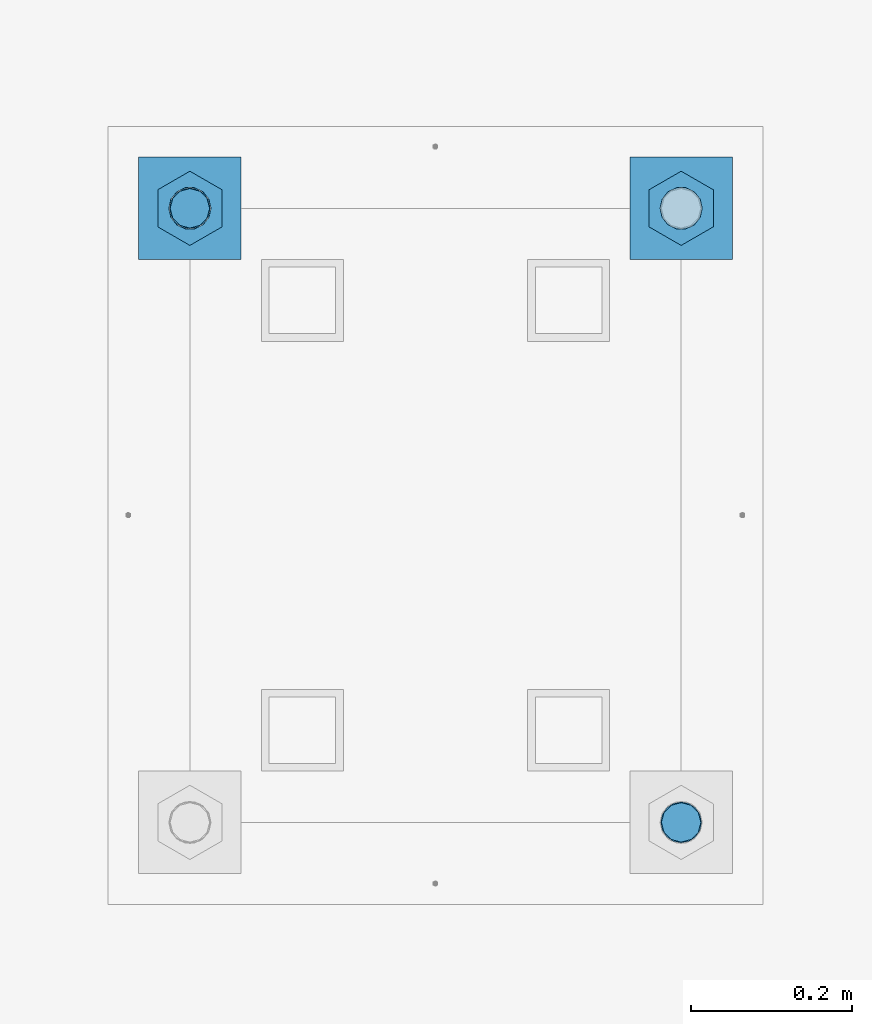
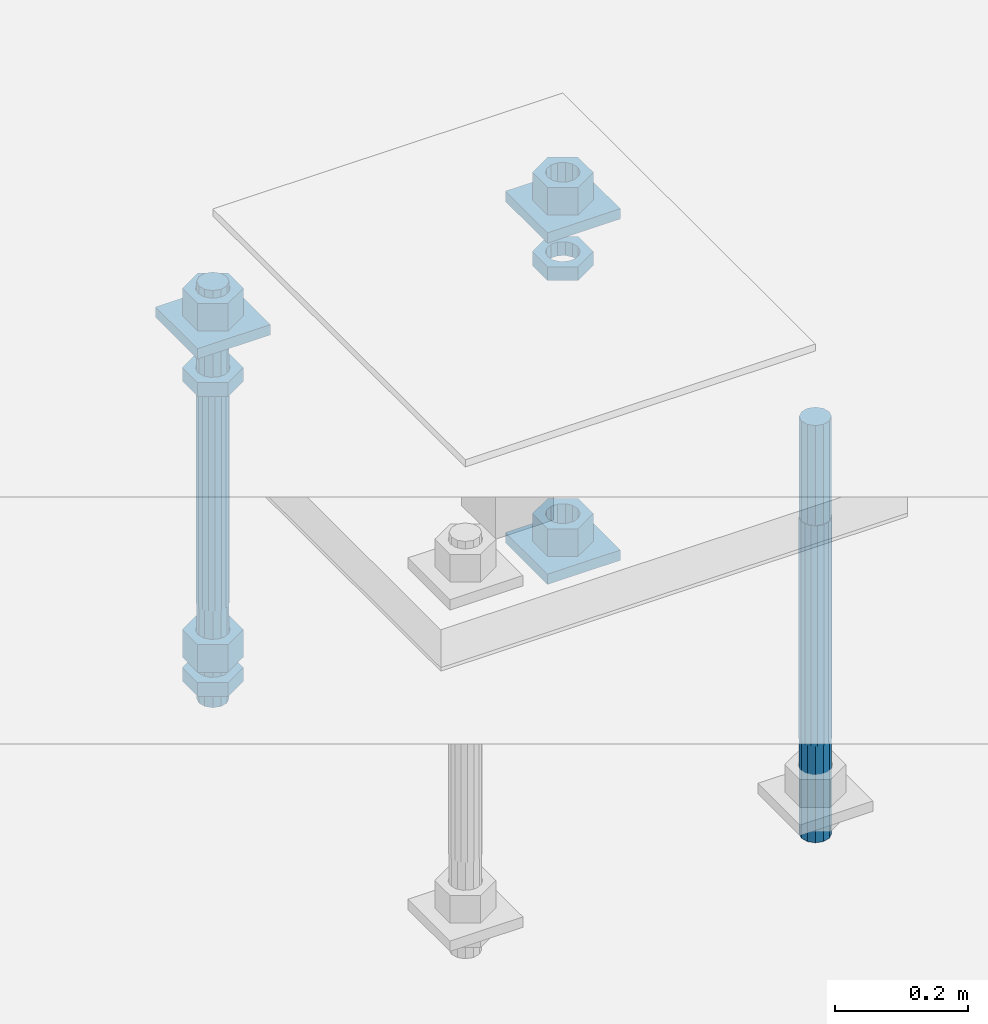
# One storey, part 2643 of 3843: 12 beams, 1 element without a shape of its own.
"""IFC2X3 building model written with IfcOpenShell, lengths in millimetres."""

from ifc_helpers import new_model, si_unit, frame, origin_with_axes, place, context, subcontext, project, spatial, faceted_brep, material, type_object, element, aggregate, save


model = new_model("IFC2X3")

# Units and contexts
model_context = context("Model", 3, precision=1e-05, world=origin_with_axes())
body_context = subcontext(model_context, "Body", "Model", "MODEL_VIEW")
ifc_project = project(units=[si_unit("LENGTHUNIT", "METRE", prefix="MILLI"), si_unit("AREAUNIT", "SQUARE_METRE"), si_unit("VOLUMEUNIT", "CUBIC_METRE"), si_unit("MASSUNIT", "GRAM", prefix="KILO"), si_unit("TIMEUNIT", "SECOND"), si_unit("PLANEANGLEUNIT", "RADIAN"), si_unit("SOLIDANGLEUNIT", "STERADIAN"), si_unit("THERMODYNAMICTEMPERATUREUNIT", "DEGREE_CELSIUS"), si_unit("LUMINOUSINTENSITYUNIT", "LUMEN")], contexts=[model_context])

# Site, building, storey
site_placement = place(None, origin_with_axes())
site = spatial("IfcSite", under=ifc_project, at=site_placement, CompositionType="ELEMENT")
building_placement = place(site_placement, origin_with_axes())
building = spatial("IfcBuilding", under=site, at=building_placement, Name="Undefined", CompositionType="ELEMENT")
storey_placement = place(building_placement, origin_with_axes())
storey = spatial("IfcBuildingStorey", under=building, at=storey_placement, Name="Undefined", CompositionType="ELEMENT", Elevation=0.0)

# Assembly, beams
assembly_placement = place(storey_placement, origin_with_axes())
assembly = element("IfcElementAssembly", 1, at=assembly_placement, inside=storey, Name="TEMPLATE", AssemblyPlace="NOTDEFINED", PredefinedType="RIGID_FRAME")
ifc_material_1 = material(Name="STEEL/A36")
beam_type_1 = type_object("IfcBeamType", PredefinedType="NOTDEFINED")
beam_1_placement = place(assembly_placement, frame((116471.7, 10883.9, 29873.575), z_axis=(0.0, 1.0, 0.0), x_axis=(-1.0, 0.0, 0.0)))
beam_1 = element("IfcBeam", 2, at=beam_1_placement, type_object=beam_type_1, material=ifc_material_1, Name="WASHER_PLATE", context=body_context, shape_type="Brep", body=[
    faceted_brep([(0.0, 9.52500000000146, -63.5), (0.0, 9.52500000000146, 63.5), (127.0, 9.52500000000146, 63.5), (127.0, 9.52500000000146, -63.5), (0.0, -9.52500000000146, 63.5), (127.0, -9.52500000000146, 63.5), (0.0, -9.52500000000146, -63.5), (127.0, -9.52500000000146, -63.5)], [[[0, 1, 2, 3]], [[1, 4, 5, 2]], [[4, 6, 7, 5]], [[6, 0, 3, 7]], [[5, 7, 3, 2]], [[6, 4, 1, 0]]]),
])
beam_2_placement = place(assembly_placement, frame((115862.099998474, 10883.9, 29873.575), z_axis=(0.0, 1.0, 0.0), x_axis=(-1.0, 0.0, 0.0)))
beam_2 = element("IfcBeam", 3, at=beam_2_placement, type_object=beam_type_1, material=ifc_material_1, Name="WASHER_PLATE", context=body_context, shape_type="Brep", body=[
    faceted_brep([(0.0, 9.52500000000146, -63.5), (0.0, 9.52500000000146, 63.5), (127.0, 9.52500000000146, 63.5), (127.0, 9.52500000000146, -63.5), (0.0, -9.52500000000146, 63.5), (127.0, -9.52500000000146, 63.5), (0.0, -9.52500000000146, -63.5), (127.0, -9.52500000000146, -63.5)], [[[0, 1, 2, 3]], [[1, 4, 5, 2]], [[4, 6, 7, 5]], [[6, 0, 3, 7]], [[5, 7, 3, 2]], [[6, 4, 1, 0]]]),
])
beam_3_placement = place(assembly_placement, frame((116471.7, 10883.9, 29244.925), z_axis=(0.0, 1.0, 0.0), x_axis=(-1.0, 0.0, 0.0)))
beam_3 = element("IfcBeam", 4, at=beam_3_placement, type_object=beam_type_1, material=ifc_material_1, Name="WASHER_PLATE", context=body_context, shape_type="Brep", body=[
    faceted_brep([(0.0, 9.52500000000146, -63.5), (0.0, 9.52500000000146, 63.5), (127.0, 9.52500000000146, 63.5), (127.0, 9.52500000000146, -63.5), (0.0, -9.52500000000146, 63.5), (127.0, -9.52500000000146, 63.5), (0.0, -9.52500000000146, -63.5), (127.0, -9.52500000000146, -63.5)], [[[0, 1, 2, 3]], [[1, 4, 5, 2]], [[4, 6, 7, 5]], [[6, 0, 3, 7]], [[5, 7, 3, 2]], [[6, 4, 1, 0]]]),
])
beam_type_2 = type_object("IfcBeamType", Name="2_HALF_NUT", PredefinedType="NOTDEFINED")
beam_4_placement = place(assembly_placement, frame((115798.599998474, 10883.9, 29787.85), z_axis=(-1.0, 0.0, 0.0), x_axis=(0.0, 0.0, -1.0)))
beam_4 = element("IfcBeam", 5, at=beam_4_placement, type_object=beam_type_2, material=ifc_material_1, Name="NUT", ObjectType="2_HALF_NUT", context=body_context, shape_type="Brep", body=[
    faceted_brep([(0.0, -46.0369987487793, 0.0), (0.0, -23.0184993743896, -39.869213104248), (25.4000000000015, -23.0184993743896, -39.869213104248), (25.4000000000015, -46.0369987487793, 0.0), (0.0, 23.0184993743896, -39.869213104248), (25.4000000000015, 23.0184993743896, -39.869213104248), (0.0, 46.0369987487793, 0.0), (25.4000000000015, 46.0369987487793, 0.0), (0.0, 23.0184993743896, 39.869213104248), (25.4000000000015, 23.0184993743896, 39.869213104248), (0.0, -23.0184993743896, 39.869213104248), (25.4000000000015, -23.0184993743896, 39.869213104248), (0.0, 0.0, 26.1940002441406), (0.0, 11.3650617044477, 23.5999013092805), (25.4000000000015, 11.3650617044477, 23.5999013092805), (25.4000000000015, 0.0, 26.1940002441406), (0.0, 20.4791109456419, 16.3316083006721), (25.4000000000015, 20.4791109456419, 16.3316083006721), (0.0, 25.5370200498292, 5.82867859874386), (25.4000000000015, 25.5370200498292, 5.82867859874386), (0.0, 25.5370200498292, -5.82867859874386), (25.4000000000015, 25.5370200498292, -5.82867859874386), (0.0, 20.4791109456419, -16.3316083006721), (25.4000000000015, 20.4791109456419, -16.3316083006721), (0.0, 11.3650617044477, -23.5999013092805), (25.4000000000015, 11.3650617044477, -23.5999013092805), (0.0, 0.0, -26.1940002441406), (25.4000000000015, 0.0, -26.1940002441406), (0.0, -11.3650617044477, -23.5999013092805), (25.4000000000015, -11.3650617044477, -23.5999013092805), (0.0, -20.4791109456419, -16.3316083006721), (25.4000000000015, -20.4791109456419, -16.3316083006721), (0.0, -25.5370200498292, -5.82867859874386), (25.4000000000015, -25.5370200498292, -5.82867859874386), (0.0, -25.5370200498292, 5.82867859874386), (25.4000000000015, -25.5370200498292, 5.82867859874386), (0.0, -20.4791109456419, 16.3316083006721), (25.4000000000015, -20.4791109456419, 16.3316083006721), (0.0, -11.3650617044477, 23.5999013092805), (25.4000000000015, -11.3650617044477, 23.5999013092805)], [[[0, 1, 2, 3]], [[1, 4, 5, 2]], [[4, 6, 7, 5]], [[6, 8, 9, 7]], [[8, 10, 11, 9]], [[10, 0, 3, 11]], [[12, 13, 14, 15]], [[13, 16, 17, 14]], [[16, 18, 19, 17]], [[18, 20, 21, 19]], [[20, 22, 23, 21]], [[22, 24, 25, 23]], [[24, 26, 27, 25]], [[26, 28, 29, 27]], [[28, 30, 31, 29]], [[30, 32, 33, 31]], [[32, 34, 35, 33]], [[34, 36, 37, 35]], [[36, 38, 39, 37]], [[38, 12, 15, 39]], [[5, 7, 9, 11, 3, 2], [17, 19, 21, 23, 25, 27, 29, 31, 33, 35, 37, 39, 15, 14]], [[10, 8, 6, 4, 1, 0], [38, 36, 34, 32, 30, 28, 26, 24, 22, 20, 18, 16, 13, 12]]]),
])
beam_5_placement = place(assembly_placement, frame((115798.599998474, 10883.9, 29235.4), z_axis=(-1.0, 0.0, 0.0), x_axis=(0.0, 0.0, -1.0)))
beam_5 = element("IfcBeam", 6, at=beam_5_placement, type_object=beam_type_2, material=ifc_material_1, Name="NUT", ObjectType="2_HALF_NUT", context=body_context, shape_type="Brep", body=[
    faceted_brep([(0.0, -46.0369987487793, 0.0), (0.0, -23.0184993743896, -39.869213104248), (25.4000000000015, -23.0184993743896, -39.869213104248), (25.4000000000015, -46.0369987487793, 0.0), (0.0, 23.0184993743896, -39.869213104248), (25.4000000000015, 23.0184993743896, -39.869213104248), (0.0, 46.0369987487793, 0.0), (25.4000000000015, 46.0369987487793, 0.0), (0.0, 23.0184993743896, 39.869213104248), (25.4000000000015, 23.0184993743896, 39.869213104248), (0.0, -23.0184993743896, 39.869213104248), (25.4000000000015, -23.0184993743896, 39.869213104248), (0.0, 0.0, 26.1940002441406), (0.0, 11.3650617044477, 23.5999013092805), (25.4000000000015, 11.3650617044477, 23.5999013092805), (25.4000000000015, 0.0, 26.1940002441406), (0.0, 20.4791109456419, 16.3316083006721), (25.4000000000015, 20.4791109456419, 16.3316083006721), (0.0, 25.5370200498292, 5.82867859874386), (25.4000000000015, 25.5370200498292, 5.82867859874386), (0.0, 25.5370200498292, -5.82867859874386), (25.4000000000015, 25.5370200498292, -5.82867859874386), (0.0, 20.4791109456419, -16.3316083006721), (25.4000000000015, 20.4791109456419, -16.3316083006721), (0.0, 11.3650617044477, -23.5999013092805), (25.4000000000015, 11.3650617044477, -23.5999013092805), (0.0, 0.0, -26.1940002441406), (25.4000000000015, 0.0, -26.1940002441406), (0.0, -11.3650617044477, -23.5999013092805), (25.4000000000015, -11.3650617044477, -23.5999013092805), (0.0, -20.4791109456419, -16.3316083006721), (25.4000000000015, -20.4791109456419, -16.3316083006721), (0.0, -25.5370200498292, -5.82867859874386), (25.4000000000015, -25.5370200498292, -5.82867859874386), (0.0, -25.5370200498292, 5.82867859874386), (25.4000000000015, -25.5370200498292, 5.82867859874386), (0.0, -20.4791109456419, 16.3316083006721), (25.4000000000015, -20.4791109456419, 16.3316083006721), (0.0, -11.3650617044477, 23.5999013092805), (25.4000000000015, -11.3650617044477, 23.5999013092805)], [[[0, 1, 2, 3]], [[1, 4, 5, 2]], [[4, 6, 7, 5]], [[6, 8, 9, 7]], [[8, 10, 11, 9]], [[10, 0, 3, 11]], [[12, 13, 14, 15]], [[13, 16, 17, 14]], [[16, 18, 19, 17]], [[18, 20, 21, 19]], [[20, 22, 23, 21]], [[22, 24, 25, 23]], [[24, 26, 27, 25]], [[26, 28, 29, 27]], [[28, 30, 31, 29]], [[30, 32, 33, 31]], [[32, 34, 35, 33]], [[34, 36, 37, 35]], [[36, 38, 39, 37]], [[38, 12, 15, 39]], [[5, 7, 9, 11, 3, 2], [17, 19, 21, 23, 25, 27, 29, 31, 33, 35, 37, 39, 15, 14]], [[10, 8, 6, 4, 1, 0], [38, 36, 34, 32, 30, 28, 26, 24, 22, 20, 18, 16, 13, 12]]]),
])
beam_6_placement = place(assembly_placement, frame((116408.2, 10883.9, 29787.85), z_axis=(-1.0, 0.0, 0.0), x_axis=(0.0, 0.0, -1.0)))
beam_6 = element("IfcBeam", 7, at=beam_6_placement, type_object=beam_type_2, material=ifc_material_1, Name="NUT", ObjectType="2_HALF_NUT", context=body_context, shape_type="Brep", body=[
    faceted_brep([(0.0, -46.0369987487793, 0.0), (0.0, -23.0184993743896, -39.869213104248), (25.4000000000015, -23.0184993743896, -39.869213104248), (25.4000000000015, -46.0369987487793, 0.0), (0.0, 23.0184993743896, -39.869213104248), (25.4000000000015, 23.0184993743896, -39.869213104248), (0.0, 46.0369987487793, 0.0), (25.4000000000015, 46.0369987487793, 0.0), (0.0, 23.0184993743896, 39.869213104248), (25.4000000000015, 23.0184993743896, 39.869213104248), (0.0, -23.0184993743896, 39.869213104248), (25.4000000000015, -23.0184993743896, 39.869213104248), (0.0, 0.0, 26.1940002441406), (0.0, 11.3650617044477, 23.5999013092805), (25.4000000000015, 11.3650617044477, 23.5999013092805), (25.4000000000015, 0.0, 26.1940002441406), (0.0, 20.4791109456419, 16.3316083006721), (25.4000000000015, 20.4791109456419, 16.3316083006721), (0.0, 25.5370200498292, 5.82867859874386), (25.4000000000015, 25.5370200498292, 5.82867859874386), (0.0, 25.5370200498292, -5.82867859874386), (25.4000000000015, 25.5370200498292, -5.82867859874386), (0.0, 20.4791109456419, -16.3316083006721), (25.4000000000015, 20.4791109456419, -16.3316083006721), (0.0, 11.3650617044477, -23.5999013092805), (25.4000000000015, 11.3650617044477, -23.5999013092805), (0.0, 0.0, -26.1940002441406), (25.4000000000015, 0.0, -26.1940002441406), (0.0, -11.3650617044477, -23.5999013092805), (25.4000000000015, -11.3650617044477, -23.5999013092805), (0.0, -20.4791109456419, -16.3316083006721), (25.4000000000015, -20.4791109456419, -16.3316083006721), (0.0, -25.5370200498292, -5.82867859874386), (25.4000000000015, -25.5370200498292, -5.82867859874386), (0.0, -25.5370200498292, 5.82867859874386), (25.4000000000015, -25.5370200498292, 5.82867859874386), (0.0, -20.4791109456419, 16.3316083006721), (25.4000000000015, -20.4791109456419, 16.3316083006721), (0.0, -11.3650617044477, 23.5999013092805), (25.4000000000015, -11.3650617044477, 23.5999013092805)], [[[0, 1, 2, 3]], [[1, 4, 5, 2]], [[4, 6, 7, 5]], [[6, 8, 9, 7]], [[8, 10, 11, 9]], [[10, 0, 3, 11]], [[12, 13, 14, 15]], [[13, 16, 17, 14]], [[16, 18, 19, 17]], [[18, 20, 21, 19]], [[20, 22, 23, 21]], [[22, 24, 25, 23]], [[24, 26, 27, 25]], [[26, 28, 29, 27]], [[28, 30, 31, 29]], [[30, 32, 33, 31]], [[32, 34, 35, 33]], [[34, 36, 37, 35]], [[36, 38, 39, 37]], [[38, 12, 15, 39]], [[5, 7, 9, 11, 3, 2], [17, 19, 21, 23, 25, 27, 29, 31, 33, 35, 37, 39, 15, 14]], [[10, 8, 6, 4, 1, 0], [38, 36, 34, 32, 30, 28, 26, 24, 22, 20, 18, 16, 13, 12]]]),
])
beam_type_3 = type_object("IfcBeamType", Name="2_HEAVY_HEX_NUT", PredefinedType="NOTDEFINED")
beam_7_placement = place(assembly_placement, frame((115798.599998474, 10883.9, 29933.9), z_axis=(-1.0, 0.0, 0.0), x_axis=(0.0, 0.0, -1.0)))
beam_7 = element("IfcBeam", 8, at=beam_7_placement, type_object=beam_type_3, material=ifc_material_1, Name="NUT", ObjectType="2_HEAVY_HEX_NUT", context=body_context, shape_type="Brep", body=[
    faceted_brep([(0.0, -46.0369987487793, 0.0), (0.0, -23.0184993743896, -39.869213104248), (50.7999999999993, -23.0184993743896, -39.869213104248), (50.7999999999993, -46.0369987487793, 0.0), (0.0, 23.0184993743896, -39.869213104248), (50.7999999999993, 23.0184993743896, -39.869213104248), (0.0, 46.0369987487793, 0.0), (50.7999999999993, 46.0369987487793, 0.0), (0.0, 23.0184993743896, 39.869213104248), (50.7999999999993, 23.0184993743896, 39.869213104248), (0.0, -23.0184993743896, 39.869213104248), (50.7999999999993, -23.0184993743896, 39.869213104248), (0.0, 0.0, 26.1940002441406), (0.0, 11.3650617044477, 23.5999013092805), (50.7999999999993, 11.3650617044477, 23.5999013092805), (50.7999999999993, 0.0, 26.1940002441406), (0.0, 20.4791109456419, 16.3316083006721), (50.7999999999993, 20.4791109456419, 16.3316083006721), (0.0, 25.5370200498292, 5.82867859874386), (50.7999999999993, 25.5370200498292, 5.82867859874386), (0.0, 25.5370200498292, -5.82867859874386), (50.7999999999993, 25.5370200498292, -5.82867859874386), (0.0, 20.4791109456419, -16.3316083006721), (50.7999999999993, 20.4791109456419, -16.3316083006721), (0.0, 11.3650617044477, -23.5999013092805), (50.7999999999993, 11.3650617044477, -23.5999013092805), (0.0, 0.0, -26.1940002441406), (50.7999999999993, 0.0, -26.1940002441406), (0.0, -11.3650617044477, -23.5999013092805), (50.7999999999993, -11.3650617044477, -23.5999013092805), (0.0, -20.4791109456419, -16.3316083006721), (50.7999999999993, -20.4791109456419, -16.3316083006721), (0.0, -25.5370200498292, -5.82867859874386), (50.7999999999993, -25.5370200498292, -5.82867859874386), (0.0, -25.5370200498292, 5.82867859874386), (50.7999999999993, -25.5370200498292, 5.82867859874386), (0.0, -20.4791109456419, 16.3316083006721), (50.7999999999993, -20.4791109456419, 16.3316083006721), (0.0, -11.3650617044477, 23.5999013092805), (50.7999999999993, -11.3650617044477, 23.5999013092805)], [[[0, 1, 2, 3]], [[1, 4, 5, 2]], [[4, 6, 7, 5]], [[6, 8, 9, 7]], [[8, 10, 11, 9]], [[10, 0, 3, 11]], [[12, 13, 14, 15]], [[13, 16, 17, 14]], [[16, 18, 19, 17]], [[18, 20, 21, 19]], [[20, 22, 23, 21]], [[22, 24, 25, 23]], [[24, 26, 27, 25]], [[26, 28, 29, 27]], [[28, 30, 31, 29]], [[30, 32, 33, 31]], [[32, 34, 35, 33]], [[34, 36, 37, 35]], [[36, 38, 39, 37]], [[38, 12, 15, 39]], [[5, 7, 9, 11, 3, 2], [17, 19, 21, 23, 25, 27, 29, 31, 33, 35, 37, 39, 15, 14]], [[10, 8, 6, 4, 1, 0], [38, 36, 34, 32, 30, 28, 26, 24, 22, 20, 18, 16, 13, 12]]]),
])
beam_8_placement = place(assembly_placement, frame((115798.599998474, 10883.9, 29305.25), z_axis=(-1.0, 0.0, 0.0), x_axis=(0.0, 0.0, -1.0)))
beam_8 = element("IfcBeam", 9, at=beam_8_placement, type_object=beam_type_3, material=ifc_material_1, Name="NUT", ObjectType="2_HEAVY_HEX_NUT", context=body_context, shape_type="Brep", body=[
    faceted_brep([(0.0, -46.0369987487793, 0.0), (0.0, -23.0184993743896, -39.869213104248), (50.7999999999993, -23.0184993743896, -39.869213104248), (50.7999999999993, -46.0369987487793, 0.0), (0.0, 23.0184993743896, -39.869213104248), (50.7999999999993, 23.0184993743896, -39.869213104248), (0.0, 46.0369987487793, 0.0), (50.7999999999993, 46.0369987487793, 0.0), (0.0, 23.0184993743896, 39.869213104248), (50.7999999999993, 23.0184993743896, 39.869213104248), (0.0, -23.0184993743896, 39.869213104248), (50.7999999999993, -23.0184993743896, 39.869213104248), (0.0, 0.0, 26.1940002441406), (0.0, 11.3650617044477, 23.5999013092805), (50.7999999999993, 11.3650617044477, 23.5999013092805), (50.7999999999993, 0.0, 26.1940002441406), (0.0, 20.4791109456419, 16.3316083006721), (50.7999999999993, 20.4791109456419, 16.3316083006721), (0.0, 25.5370200498292, 5.82867859874386), (50.7999999999993, 25.5370200498292, 5.82867859874386), (0.0, 25.5370200498292, -5.82867859874386), (50.7999999999993, 25.5370200498292, -5.82867859874386), (0.0, 20.4791109456419, -16.3316083006721), (50.7999999999993, 20.4791109456419, -16.3316083006721), (0.0, 11.3650617044477, -23.5999013092805), (50.7999999999993, 11.3650617044477, -23.5999013092805), (0.0, 0.0, -26.1940002441406), (50.7999999999993, 0.0, -26.1940002441406), (0.0, -11.3650617044477, -23.5999013092805), (50.7999999999993, -11.3650617044477, -23.5999013092805), (0.0, -20.4791109456419, -16.3316083006721), (50.7999999999993, -20.4791109456419, -16.3316083006721), (0.0, -25.5370200498292, -5.82867859874386), (50.7999999999993, -25.5370200498292, -5.82867859874386), (0.0, -25.5370200498292, 5.82867859874386), (50.7999999999993, -25.5370200498292, 5.82867859874386), (0.0, -20.4791109456419, 16.3316083006721), (50.7999999999993, -20.4791109456419, 16.3316083006721), (0.0, -11.3650617044477, 23.5999013092805), (50.7999999999993, -11.3650617044477, 23.5999013092805)], [[[0, 1, 2, 3]], [[1, 4, 5, 2]], [[4, 6, 7, 5]], [[6, 8, 9, 7]], [[8, 10, 11, 9]], [[10, 0, 3, 11]], [[12, 13, 14, 15]], [[13, 16, 17, 14]], [[16, 18, 19, 17]], [[18, 20, 21, 19]], [[20, 22, 23, 21]], [[22, 24, 25, 23]], [[24, 26, 27, 25]], [[26, 28, 29, 27]], [[28, 30, 31, 29]], [[30, 32, 33, 31]], [[32, 34, 35, 33]], [[34, 36, 37, 35]], [[36, 38, 39, 37]], [[38, 12, 15, 39]], [[5, 7, 9, 11, 3, 2], [17, 19, 21, 23, 25, 27, 29, 31, 33, 35, 37, 39, 15, 14]], [[10, 8, 6, 4, 1, 0], [38, 36, 34, 32, 30, 28, 26, 24, 22, 20, 18, 16, 13, 12]]]),
])
beam_9_placement = place(assembly_placement, frame((116408.2, 10883.9, 29933.9), z_axis=(-1.0, 0.0, 0.0), x_axis=(0.0, 0.0, -1.0)))
beam_9 = element("IfcBeam", 10, at=beam_9_placement, type_object=beam_type_3, material=ifc_material_1, Name="NUT", ObjectType="2_HEAVY_HEX_NUT", context=body_context, shape_type="Brep", body=[
    faceted_brep([(0.0, -46.0369987487793, 0.0), (0.0, -23.0184993743896, -39.869213104248), (50.7999999999993, -23.0184993743896, -39.869213104248), (50.7999999999993, -46.0369987487793, 0.0), (0.0, 23.0184993743896, -39.869213104248), (50.7999999999993, 23.0184993743896, -39.869213104248), (0.0, 46.0369987487793, 0.0), (50.7999999999993, 46.0369987487793, 0.0), (0.0, 23.0184993743896, 39.869213104248), (50.7999999999993, 23.0184993743896, 39.869213104248), (0.0, -23.0184993743896, 39.869213104248), (50.7999999999993, -23.0184993743896, 39.869213104248), (0.0, 0.0, 26.1940002441406), (0.0, 11.3650617044477, 23.5999013092805), (50.7999999999993, 11.3650617044477, 23.5999013092805), (50.7999999999993, 0.0, 26.1940002441406), (0.0, 20.4791109456419, 16.3316083006721), (50.7999999999993, 20.4791109456419, 16.3316083006721), (0.0, 25.5370200498292, 5.82867859874386), (50.7999999999993, 25.5370200498292, 5.82867859874386), (0.0, 25.5370200498292, -5.82867859874386), (50.7999999999993, 25.5370200498292, -5.82867859874386), (0.0, 20.4791109456419, -16.3316083006721), (50.7999999999993, 20.4791109456419, -16.3316083006721), (0.0, 11.3650617044477, -23.5999013092805), (50.7999999999993, 11.3650617044477, -23.5999013092805), (0.0, 0.0, -26.1940002441406), (50.7999999999993, 0.0, -26.1940002441406), (0.0, -11.3650617044477, -23.5999013092805), (50.7999999999993, -11.3650617044477, -23.5999013092805), (0.0, -20.4791109456419, -16.3316083006721), (50.7999999999993, -20.4791109456419, -16.3316083006721), (0.0, -25.5370200498292, -5.82867859874386), (50.7999999999993, -25.5370200498292, -5.82867859874386), (0.0, -25.5370200498292, 5.82867859874386), (50.7999999999993, -25.5370200498292, 5.82867859874386), (0.0, -20.4791109456419, 16.3316083006721), (50.7999999999993, -20.4791109456419, 16.3316083006721), (0.0, -11.3650617044477, 23.5999013092805), (50.7999999999993, -11.3650617044477, 23.5999013092805)], [[[0, 1, 2, 3]], [[1, 4, 5, 2]], [[4, 6, 7, 5]], [[6, 8, 9, 7]], [[8, 10, 11, 9]], [[10, 0, 3, 11]], [[12, 13, 14, 15]], [[13, 16, 17, 14]], [[16, 18, 19, 17]], [[18, 20, 21, 19]], [[20, 22, 23, 21]], [[22, 24, 25, 23]], [[24, 26, 27, 25]], [[26, 28, 29, 27]], [[28, 30, 31, 29]], [[30, 32, 33, 31]], [[32, 34, 35, 33]], [[34, 36, 37, 35]], [[36, 38, 39, 37]], [[38, 12, 15, 39]], [[5, 7, 9, 11, 3, 2], [17, 19, 21, 23, 25, 27, 29, 31, 33, 35, 37, 39, 15, 14]], [[10, 8, 6, 4, 1, 0], [38, 36, 34, 32, 30, 28, 26, 24, 22, 20, 18, 16, 13, 12]]]),
])
beam_10_placement = place(assembly_placement, frame((116408.2, 10883.9, 29305.25), z_axis=(-1.0, 0.0, 0.0), x_axis=(0.0, 0.0, -1.0)))
beam_10 = element("IfcBeam", 11, at=beam_10_placement, type_object=beam_type_3, material=ifc_material_1, Name="NUT", ObjectType="2_HEAVY_HEX_NUT", context=body_context, shape_type="Brep", body=[
    faceted_brep([(0.0, -46.0369987487793, 0.0), (0.0, -23.0184993743896, -39.869213104248), (50.7999999999993, -23.0184993743896, -39.869213104248), (50.7999999999993, -46.0369987487793, 0.0), (0.0, 23.0184993743896, -39.869213104248), (50.7999999999993, 23.0184993743896, -39.869213104248), (0.0, 46.0369987487793, 0.0), (50.7999999999993, 46.0369987487793, 0.0), (0.0, 23.0184993743896, 39.869213104248), (50.7999999999993, 23.0184993743896, 39.869213104248), (0.0, -23.0184993743896, 39.869213104248), (50.7999999999993, -23.0184993743896, 39.869213104248), (0.0, 0.0, 26.1940002441406), (0.0, 11.3650617044477, 23.5999013092805), (50.7999999999993, 11.3650617044477, 23.5999013092805), (50.7999999999993, 0.0, 26.1940002441406), (0.0, 20.4791109456419, 16.3316083006721), (50.7999999999993, 20.4791109456419, 16.3316083006721), (0.0, 25.5370200498292, 5.82867859874386), (50.7999999999993, 25.5370200498292, 5.82867859874386), (0.0, 25.5370200498292, -5.82867859874386), (50.7999999999993, 25.5370200498292, -5.82867859874386), (0.0, 20.4791109456419, -16.3316083006721), (50.7999999999993, 20.4791109456419, -16.3316083006721), (0.0, 11.3650617044477, -23.5999013092805), (50.7999999999993, 11.3650617044477, -23.5999013092805), (0.0, 0.0, -26.1940002441406), (50.7999999999993, 0.0, -26.1940002441406), (0.0, -11.3650617044477, -23.5999013092805), (50.7999999999993, -11.3650617044477, -23.5999013092805), (0.0, -20.4791109456419, -16.3316083006721), (50.7999999999993, -20.4791109456419, -16.3316083006721), (0.0, -25.5370200498292, -5.82867859874386), (50.7999999999993, -25.5370200498292, -5.82867859874386), (0.0, -25.5370200498292, 5.82867859874386), (50.7999999999993, -25.5370200498292, 5.82867859874386), (0.0, -20.4791109456419, 16.3316083006721), (50.7999999999993, -20.4791109456419, 16.3316083006721), (0.0, -11.3650617044477, 23.5999013092805), (50.7999999999993, -11.3650617044477, 23.5999013092805)], [[[0, 1, 2, 3]], [[1, 4, 5, 2]], [[4, 6, 7, 5]], [[6, 8, 9, 7]], [[8, 10, 11, 9]], [[10, 0, 3, 11]], [[12, 13, 14, 15]], [[13, 16, 17, 14]], [[16, 18, 19, 17]], [[18, 20, 21, 19]], [[20, 22, 23, 21]], [[22, 24, 25, 23]], [[24, 26, 27, 25]], [[26, 28, 29, 27]], [[28, 30, 31, 29]], [[30, 32, 33, 31]], [[32, 34, 35, 33]], [[34, 36, 37, 35]], [[36, 38, 39, 37]], [[38, 12, 15, 39]], [[5, 7, 9, 11, 3, 2], [17, 19, 21, 23, 25, 27, 29, 31, 33, 35, 37, 39, 15, 14]], [[10, 8, 6, 4, 1, 0], [38, 36, 34, 32, 30, 28, 26, 24, 22, 20, 18, 16, 13, 12]]]),
])
ifc_material_2 = material()
beam_type_4 = type_object("IfcBeamType", PredefinedType="NOTDEFINED")
beam_11_placement = place(assembly_placement, frame((115798.599998474, 10883.9, 29762.45), z_axis=(-1.0, 0.0, 0.0), x_axis=(0.0, 0.0, -1.0)))
beam_11 = element("IfcBeam", 12, at=beam_11_placement, type_object=beam_type_4, material=ifc_material_2, Name="ANCHOR_ROD", context=body_context, shape_type="Brep", body=[
    faceted_brep([(-184.150000000001, -21.217622392709, 12.25), (-184.150000000001, -12.2499999999854, 21.2176223927163), (-184.150000000001, 1.45519152283669e-11, 24.5), (-184.150000000001, 12.2500000000146, 21.2176223927163), (-184.150000000001, 21.2176223927381, 12.25), (-184.150000000001, 24.5000000000146, 0.0), (-184.150000000001, 21.2176223927381, -12.25), (-184.150000000001, 12.2500000000146, -21.2176223927163), (-184.150000000001, 1.45519152283669e-11, -24.5), (-184.150000000001, -12.2499999999854, -21.2176223927163), (-184.150000000001, -21.217622392709, -12.25), (-184.150000000001, -24.4999999999854, 0.0), (0.0, 24.5000000000146, 0.0), (0.0, 21.2176223927381, -12.25), (0.0, 12.2500000000146, -21.2176223927163), (0.0, 1.45519152283669e-11, -24.5), (0.0, -12.2499999999854, -21.2176223927163), (0.0, -21.217622392709, -12.25), (0.0, -24.4999999999854, 0.0), (0.0, -21.217622392709, 12.25), (0.0, -12.2499999999854, 21.2176223927163), (0.0, 1.45519152283669e-11, 24.5), (0.0, 12.2500000000146, 21.2176223927163), (0.0, 21.2176223927381, 12.25), (0.0, -23.4665401257807, 9.72015918207035), (0.0, -17.9605122421344, 17.9605122421417), (0.0, -9.72015918207762, 23.466540125788), (0.0, 0.0, 25.4000000000015), (0.0, 9.72015918207762, 23.466540125788), (0.0, 17.9605122421344, 17.9605122421417), (0.0, 23.4665401257807, 9.72015918207035), (0.0, 25.3999996185303, 0.0), (0.0, 23.4665401257807, -9.72015918207035), (0.0, 17.9605122421344, -17.9605122421417), (0.0, 9.72015918207762, -23.466540125788), (0.0, 0.0, -25.4000000000015), (0.0, -9.72015918207762, -23.466540125788), (0.0, -17.9605122421344, -17.9605122421417), (0.0, -23.4665401257807, -9.72015918207035), (0.0, -25.3999996185303, 0.0), (406.399999999998, -25.3999999999942, 0.0), (406.399999999998, -23.4665401257807, 9.72015918207035), (406.399999999998, -17.9605122421344, 17.9605122421417), (406.399999999998, -9.72015918207762, 23.466540125788), (406.399999999998, 0.0, 25.4000000000015), (406.399999999998, 9.72015918207762, 23.466540125788), (406.399999999998, 17.9605122421344, 17.9605122421417), (406.399999999998, 23.4665401257807, 9.72015918207035), (406.399999999998, 25.3999999999942, 0.0), (406.399999999998, 23.4665401257807, -9.72015918207035), (406.399999999998, 17.9605122421344, -17.9605122421417), (406.399999999998, 9.72015918207762, -23.466540125788), (406.399999999998, 0.0, -25.4000000000015), (406.399999999998, -9.72015918207762, -23.466540125788), (406.399999999998, -17.9605122421344, -17.9605122421417), (406.399999999998, -23.4665401257807, -9.72015918207035), (406.399999999998, -12.2499999999854, 21.2176223927163), (406.399999999998, 1.45519152283669e-11, 24.5), (406.399999999998, 12.2500000000146, 21.2176223927163), (406.399999999998, 21.2176223927381, 12.25), (406.399999999998, 24.5000000000146, 0.0), (406.399999999998, 21.2176223927381, -12.25), (406.399999999998, 12.2500000000146, -21.2176223927163), (406.399999999998, 1.45519152283669e-11, -24.5), (406.399999999998, -12.2499999999854, -21.2176223927163), (406.399999999998, -21.217622392709, -12.25), (406.399999999998, -24.4999999999854, 0.0), (406.399999999998, -21.217622392709, 12.25), (584.200000000001, -12.2499999999854, -21.2176223927163), (584.200000000001, 1.45519152283669e-11, -24.5), (584.200000000001, 12.2500000000146, -21.2176223927163), (584.200000000001, 21.2176223927381, -12.25), (584.200000000001, 24.5000000000146, 0.0), (584.200000000001, 21.2176223927381, 12.25), (584.200000000001, 12.2500000000146, 21.2176223927163), (584.200000000001, 1.45519152283669e-11, 24.5), (584.200000000001, -12.2499999999854, 21.2176223927163), (584.200000000001, -21.217622392709, 12.25), (584.200000000001, -24.4999999999854, 0.0), (584.200000000001, -21.217622392709, -12.25)], [[[0, 1, 2, 3, 4, 5, 6, 7, 8, 9, 10, 11]], [[6, 5, 12, 13]], [[7, 6, 13, 14]], [[8, 7, 14, 15]], [[9, 8, 15, 16]], [[10, 9, 16, 17]], [[11, 10, 17, 18]], [[0, 11, 18, 19]], [[1, 0, 19, 20]], [[2, 1, 20, 21]], [[3, 2, 21, 22]], [[4, 3, 22, 23]], [[5, 4, 23, 12]], [[24, 25, 26, 27, 28, 29, 30, 31, 32, 33, 34, 35, 36, 37, 38, 39], [22, 21, 20, 19, 18, 17, 16, 15, 14, 13, 12, 23]], [[24, 39, 40, 41]], [[25, 24, 41, 42]], [[26, 25, 42, 43]], [[27, 26, 43, 44]], [[28, 27, 44, 45]], [[29, 28, 45, 46]], [[30, 29, 46, 47]], [[31, 30, 47, 48]], [[32, 31, 48, 49]], [[33, 32, 49, 50]], [[34, 33, 50, 51]], [[35, 34, 51, 52]], [[36, 35, 52, 53]], [[37, 36, 53, 54]], [[38, 37, 54, 55]], [[39, 38, 55, 40]], [[54, 53, 52, 51, 50, 49, 48, 47, 46, 45, 44, 43, 42, 41, 40, 55], [56, 57, 58, 59, 60, 61, 62, 63, 64, 65, 66, 67]], [[68, 69, 70, 71, 72, 73, 74, 75, 76, 77, 78, 79]], [[76, 75, 57, 56]], [[77, 76, 56, 67]], [[78, 77, 67, 66]], [[79, 78, 66, 65]], [[68, 79, 65, 64]], [[69, 68, 64, 63]], [[70, 69, 63, 62]], [[71, 70, 62, 61]], [[72, 71, 61, 60]], [[73, 72, 60, 59]], [[74, 73, 59, 58]], [[75, 74, 58, 57]]]),
])
beam_12_placement = place(assembly_placement, frame((116408.2, 10121.9, 29762.45), z_axis=(-1.0, 0.0, 0.0), x_axis=(0.0, 0.0, -1.0)))
beam_12 = element("IfcBeam", 13, at=beam_12_placement, type_object=beam_type_4, material=ifc_material_2, Name="ANCHOR_ROD", context=body_context, shape_type="Brep", body=[
    faceted_brep([(-184.150000000001, -21.217622392709, 12.25), (-184.150000000001, -12.2499999999854, 21.2176223927163), (-184.150000000001, 1.45519152283669e-11, 24.5), (-184.150000000001, 12.2500000000146, 21.2176223927163), (-184.150000000001, 21.2176223927381, 12.25), (-184.150000000001, 24.5000000000146, 0.0), (-184.150000000001, 21.2176223927381, -12.25), (-184.150000000001, 12.2500000000146, -21.2176223927163), (-184.150000000001, 1.45519152283669e-11, -24.5), (-184.150000000001, -12.2499999999854, -21.2176223927163), (-184.150000000001, -21.217622392709, -12.25), (-184.150000000001, -24.4999999999854, 0.0), (0.0, 24.5000000000146, 0.0), (0.0, 21.2176223927381, -12.25), (0.0, 12.2500000000146, -21.2176223927163), (0.0, 1.45519152283669e-11, -24.5), (0.0, -12.2499999999854, -21.2176223927163), (0.0, -21.217622392709, -12.25), (0.0, -24.4999999999854, 0.0), (0.0, -21.217622392709, 12.25), (0.0, -12.2499999999854, 21.2176223927163), (0.0, 1.45519152283669e-11, 24.5), (0.0, 12.2500000000146, 21.2176223927163), (0.0, 21.2176223927381, 12.25), (0.0, -23.4665401257807, 9.72015918207035), (0.0, -17.9605122421344, 17.9605122421417), (0.0, -9.72015918207762, 23.466540125788), (0.0, 0.0, 25.4000000000015), (0.0, 9.72015918207762, 23.466540125788), (0.0, 17.9605122421344, 17.9605122421417), (0.0, 23.4665401257807, 9.72015918207035), (0.0, 25.3999996185303, 0.0), (0.0, 23.4665401257807, -9.72015918207035), (0.0, 17.9605122421344, -17.9605122421417), (0.0, 9.72015918207762, -23.466540125788), (0.0, 0.0, -25.4000000000015), (0.0, -9.72015918207762, -23.466540125788), (0.0, -17.9605122421344, -17.9605122421417), (0.0, -23.4665401257807, -9.72015918207035), (0.0, -25.3999996185303, 0.0), (406.399999999998, -25.3999999999942, 0.0), (406.399999999998, -23.4665401257807, 9.72015918207035), (406.399999999998, -17.9605122421344, 17.9605122421417), (406.399999999998, -9.72015918207762, 23.466540125788), (406.399999999998, 0.0, 25.4000000000015), (406.399999999998, 9.72015918207762, 23.466540125788), (406.399999999998, 17.9605122421344, 17.9605122421417), (406.399999999998, 23.4665401257807, 9.72015918207035), (406.399999999998, 25.3999999999942, 0.0), (406.399999999998, 23.4665401257807, -9.72015918207035), (406.399999999998, 17.9605122421344, -17.9605122421417), (406.399999999998, 9.72015918207762, -23.466540125788), (406.399999999998, 0.0, -25.4000000000015), (406.399999999998, -9.72015918207762, -23.466540125788), (406.399999999998, -17.9605122421344, -17.9605122421417), (406.399999999998, -23.4665401257807, -9.72015918207035), (406.399999999998, -12.2499999999854, 21.2176223927163), (406.399999999998, 1.45519152283669e-11, 24.5), (406.399999999998, 12.2500000000146, 21.2176223927163), (406.399999999998, 21.2176223927381, 12.25), (406.399999999998, 24.5000000000146, 0.0), (406.399999999998, 21.2176223927381, -12.25), (406.399999999998, 12.2500000000146, -21.2176223927163), (406.399999999998, 1.45519152283669e-11, -24.5), (406.399999999998, -12.2499999999854, -21.2176223927163), (406.399999999998, -21.217622392709, -12.25), (406.399999999998, -24.4999999999854, 0.0), (406.399999999998, -21.217622392709, 12.25), (584.200000000001, -12.2499999999854, -21.2176223927163), (584.200000000001, 1.45519152283669e-11, -24.5), (584.200000000001, 12.2500000000146, -21.2176223927163), (584.200000000001, 21.2176223927381, -12.25), (584.200000000001, 24.5000000000146, 0.0), (584.200000000001, 21.2176223927381, 12.25), (584.200000000001, 12.2500000000146, 21.2176223927163), (584.200000000001, 1.45519152283669e-11, 24.5), (584.200000000001, -12.2499999999854, 21.2176223927163), (584.200000000001, -21.217622392709, 12.25), (584.200000000001, -24.4999999999854, 0.0), (584.200000000001, -21.217622392709, -12.25)], [[[0, 1, 2, 3, 4, 5, 6, 7, 8, 9, 10, 11]], [[6, 5, 12, 13]], [[7, 6, 13, 14]], [[8, 7, 14, 15]], [[9, 8, 15, 16]], [[10, 9, 16, 17]], [[11, 10, 17, 18]], [[0, 11, 18, 19]], [[1, 0, 19, 20]], [[2, 1, 20, 21]], [[3, 2, 21, 22]], [[4, 3, 22, 23]], [[5, 4, 23, 12]], [[24, 25, 26, 27, 28, 29, 30, 31, 32, 33, 34, 35, 36, 37, 38, 39], [22, 21, 20, 19, 18, 17, 16, 15, 14, 13, 12, 23]], [[24, 39, 40, 41]], [[25, 24, 41, 42]], [[26, 25, 42, 43]], [[27, 26, 43, 44]], [[28, 27, 44, 45]], [[29, 28, 45, 46]], [[30, 29, 46, 47]], [[31, 30, 47, 48]], [[32, 31, 48, 49]], [[33, 32, 49, 50]], [[34, 33, 50, 51]], [[35, 34, 51, 52]], [[36, 35, 52, 53]], [[37, 36, 53, 54]], [[38, 37, 54, 55]], [[39, 38, 55, 40]], [[54, 53, 52, 51, 50, 49, 48, 47, 46, 45, 44, 43, 42, 41, 40, 55], [56, 57, 58, 59, 60, 61, 62, 63, 64, 65, 66, 67]], [[68, 69, 70, 71, 72, 73, 74, 75, 76, 77, 78, 79]], [[76, 75, 57, 56]], [[77, 76, 56, 67]], [[78, 77, 67, 66]], [[79, 78, 66, 65]], [[68, 79, 65, 64]], [[69, 68, 64, 63]], [[70, 69, 63, 62]], [[71, 70, 62, 61]], [[72, 71, 61, 60]], [[73, 72, 60, 59]], [[74, 73, 59, 58]], [[75, 74, 58, 57]]]),
])
aggregate(assembly, [beam_1, beam_2, beam_4, beam_7, beam_8, beam_5, beam_11, beam_12, beam_3, beam_6, beam_9, beam_10])

save(model, "model.ifc")
